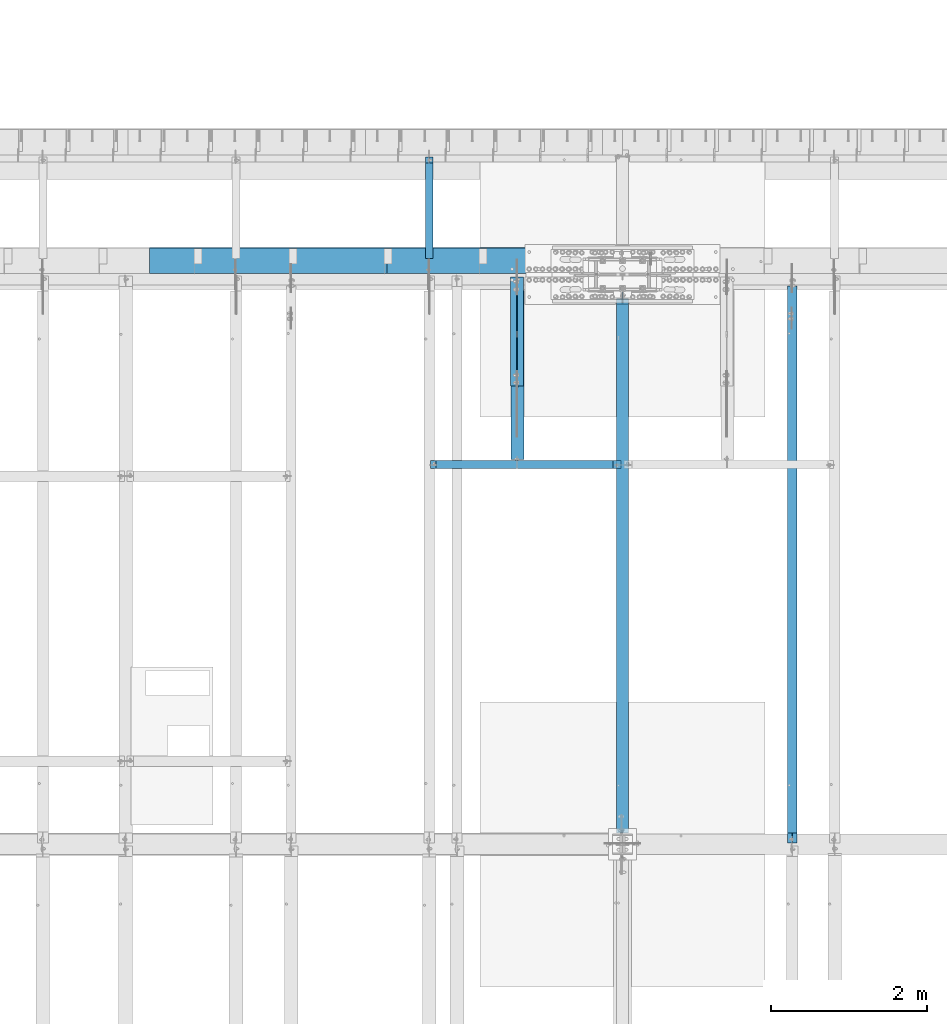
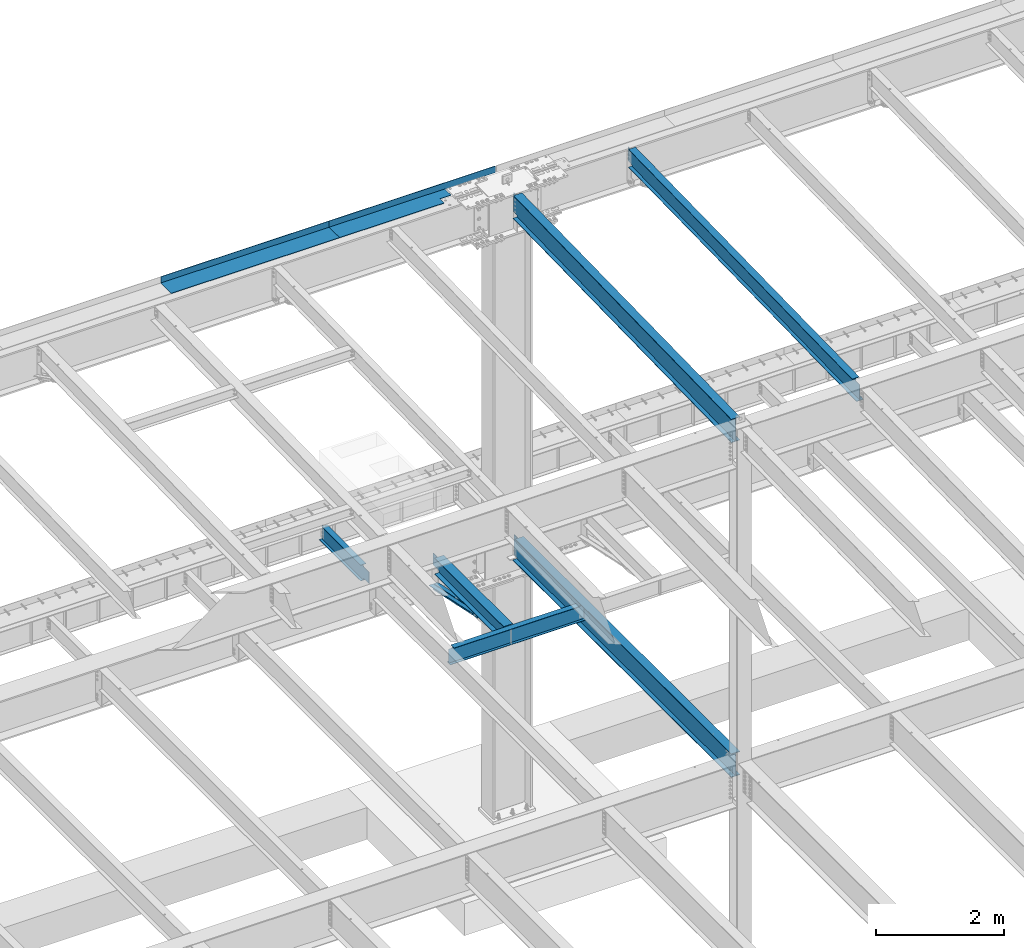
# One storey, part 1128 of 1763: 10 beams, 8 elements without a shape of their own.
"""IFC2X3 building model written with IfcOpenShell, lengths in millimetres."""

from ifc_helpers import new_model, si_unit, frame, origin_with_axes, place, context, subcontext, project, spatial, faceted_brep, material, type_object, element, aggregate, save


model = new_model("IFC2X3")

# Units and contexts
model_context = context("Model", 3, precision=1e-05, world=origin_with_axes())
body_context = subcontext(model_context, "Body", "Model", "MODEL_VIEW")
ifc_project = project(units=[si_unit("LENGTHUNIT", "METRE", prefix="MILLI"), si_unit("AREAUNIT", "SQUARE_METRE"), si_unit("VOLUMEUNIT", "CUBIC_METRE"), si_unit("MASSUNIT", "GRAM", prefix="KILO"), si_unit("TIMEUNIT", "SECOND"), si_unit("PLANEANGLEUNIT", "RADIAN"), si_unit("SOLIDANGLEUNIT", "STERADIAN"), si_unit("THERMODYNAMICTEMPERATUREUNIT", "DEGREE_CELSIUS"), si_unit("LUMINOUSINTENSITYUNIT", "LUMEN")], contexts=[model_context])

# Site, building, storey
site_placement = place(None, origin_with_axes())
site = spatial("IfcSite", under=ifc_project, at=site_placement, CompositionType="ELEMENT")
building_placement = place(site_placement, origin_with_axes())
building = spatial("IfcBuilding", under=site, at=building_placement, Name="Undefined", CompositionType="ELEMENT")
storey_placement = place(building_placement, origin_with_axes())
storey = spatial("IfcBuildingStorey", under=building, at=storey_placement, Name="Undefined", CompositionType="ELEMENT", Elevation=0.0)

# Assembly, beam
assembly_1_placement = place(storey_placement, origin_with_axes())
assembly_1 = element("IfcElementAssembly", 1, at=assembly_1_placement, inside=storey, Name="BEAM", AssemblyPlace="NOTDEFINED", PredefinedType="RIGID_FRAME")
ifc_material_1 = material(Name="STEEL/A992")
beam_type_1 = type_object("IfcBeamType", Name="W14X22", PredefinedType="NOTDEFINED")
beam_1_placement = place(assembly_1_placement, frame((-70311.7172736983, 44809.2121579121, 11421.5633921212), z_axis=(0.0, -0.0206852279954837, 0.999786037781472), x_axis=(0.0, 0.999786037781472, 0.0206852279954825)))
beam_1 = element("IfcBeam", 2, at=beam_1_placement, type_object=beam_type_1, material=ifc_material_1, Name="BEAM", ObjectType="W14X22", context=body_context, shape_type="Brep", body=[
    faceted_brep([(7162.77359555585, -3.17500000000291, -166.687500001777), (7162.77359555585, -63.5, -166.687500001777), (7162.77359555585, -63.5, -174.625000001772), (7162.77359555585, 63.5, -174.625000001772), (7162.77359555585, 63.5, -166.687500001777), (7162.77359555585, 3.17500000000291, -166.687500001777), (7162.77359555586, 3.17500000000291, -155.574999838074), (7162.77359555586, -3.17500000000291, -155.574999838074), (7163.74032547845, 3.17500000000291, -150.714920320039), (7163.74032547845, -3.17500000000291, -150.714920320039), (7166.49333937895, 3.17500000000291, -146.594743851894), (7166.49333937895, -3.17500000000291, -146.594743851894), (7170.61351584714, 3.17500000000291, -143.841729951426), (7170.61351584714, -3.17500000000291, -143.841729951426), (7175.47359536523, 3.17500000000291, -142.87500002884), (7175.47359536523, -3.17500000000291, -142.87500002884), (7289.55462988591, -3.17500000000291, -142.875000028898), (7289.55462988591, 3.17500000000291, -142.875000028898), (148.791145859177, 3.17500000000291, 166.687499999833), (148.791145859177, 63.5, 166.687499999833), (7169.123595556, 63.5, 166.68749999797), (7169.123595556, 3.17500000000291, 166.68749999797), (11.9924390219312, 3.17500000000291, -166.687499999878), (11.9924390219312, 63.5, -166.687499999878), (11.8282148869548, 63.5, -174.624999999871), (11.8282148869548, -63.5, -174.624999999871), (11.9924390219312, -63.5, -166.687499999878), (11.9924390219312, -3.17500000000291, -166.687499999878), (17.9976630864912, -3.17500000000291, 123.56500167838), (17.9976630864912, 3.17500000000291, 123.56500167838), (136.091146049795, -3.17500000000291, 123.565001678358), (136.091146049795, 3.17500000000291, 123.565001678358), (140.951225567893, -3.17500000000291, 124.531731600942), (140.951225567893, 3.17500000000291, 124.531731600942), (145.071402036083, -3.17500000000291, 127.284745501414), (145.071402036083, 3.17500000000291, 127.284745501414), (147.824415936586, -3.17500000000291, 131.404921969557), (147.824415936586, 3.17500000000291, 131.404921969557), (148.791145859177, -3.17500000000291, 136.265001487593), (148.791145859177, 3.17500000000291, 136.265001487593), (148.79114585917, -63.5, 174.624999999827), (148.79114585917, 63.5, 174.624999999827), (148.791145859177, -3.17500000000291, 166.687499999833), (148.791145859177, -63.5, 166.687499999833), (7169.123595556, -3.17500000000291, 166.68749999797), (7169.123595556, -63.5, 166.68749999797), (7169.123595556, -63.5, 174.624999997965), (7169.123595556, 63.5, 174.624999997965), (7169.123595556, -3.17500000000291, 142.875000542512), (7169.123595556, 3.17500000000291, 142.875000542512), (7170.0903254786, -3.17500000000291, 138.014921024478), (7170.0903254786, 3.17500000000291, 138.014921024478), (7172.8433393791, -3.17500000000291, 133.894744556334), (7172.8433393791, 3.17500000000291, 133.894744556334), (7176.96351584728, -3.17500000000291, 131.14173065586), (7176.96351584728, 3.17500000000291, 131.14173065586), (7181.82359536537, -3.17500000000291, 130.175000733272), (7181.82359536537, 3.17500000000291, 130.175000733272), (7295.20394014482, -3.17500000000291, 130.17500073325), (7295.20394014482, 3.17500000000291, 130.17500073325)], [[[0, 1, 2, 3, 4, 5, 6, 7]], [[7, 6, 8, 9]], [[9, 8, 10, 11]], [[11, 10, 12, 13]], [[13, 12, 14, 15]], [[16, 15, 14, 17]], [[18, 19, 20, 21]], [[22, 23, 24, 25, 26, 27, 28, 29]], [[30, 31, 29, 28]], [[32, 33, 31, 30]], [[34, 35, 33, 32]], [[36, 37, 35, 34]], [[38, 39, 37, 36]], [[40, 41, 19, 18, 39, 38, 42, 43]], [[43, 42, 44, 45]], [[40, 43, 45, 46]], [[41, 40, 46, 47]], [[19, 41, 47, 20]], [[46, 45, 44, 48, 49, 21, 20, 47]], [[50, 51, 49, 48]], [[52, 53, 51, 50]], [[54, 55, 53, 52]], [[56, 57, 55, 54]], [[58, 59, 57, 56]], [[59, 58, 16, 17]], [[12, 10, 8, 6, 5, 22, 29, 31, 33, 35, 37, 39, 18, 21, 49, 51, 53, 55, 57, 59, 17, 14]], [[23, 22, 5, 4]], [[24, 23, 4, 3]], [[25, 24, 3, 2]], [[26, 25, 2, 1]], [[27, 26, 1, 0]], [[58, 56, 54, 52, 50, 48, 44, 42, 38, 36, 34, 32, 30, 28, 27, 0, 7, 9, 11, 13, 15, 16]]]),
])
aggregate(assembly_1, [beam_1])

# Assembly, beams
assembly_2_placement = place(storey_placement, origin_with_axes())
assembly_2 = element("IfcElementAssembly", 3, at=assembly_2_placement, inside=storey, Name="ANGLE BRACE", AssemblyPlace="NOTDEFINED", PredefinedType="RIGID_FRAME")
ifc_material_2 = material(Name="STEEL/A36")
beam_type_2 = type_object("IfcBeamType", Name="L4X3X5/16", PredefinedType="NOTDEFINED")
beam_2_placement = place(assembly_2_placement, frame((-73888.0372736984, 50680.4564530846, 4820.75267554856), z_axis=(0.0, -0.2072236520035, -0.978293595016513), x_axis=(0.0, 0.978293600950479, -0.20722362398951)))
beam_2 = element("IfcBeam", 4, at=beam_2_placement, type_object=beam_type_2, material=ifc_material_2, Name="ANGLE BRACE", ObjectType="L4X3X5/16", context=body_context, shape_type="Brep", body=[
    faceted_brep([(1.45519152283669e-10, 38.0999999999985, -50.7999999999993), (1.45519152283669e-10, 38.0999999999985, 50.7999999999993), (1427.42255777739, 38.0999999999985, 50.7999999995518), (1427.42255777754, 38.0999999999985, -50.8000000004868), (-7.27595761418343e-11, 30.1624999999985, 50.8000000000211), (1427.42255777739, 30.1624999999985, 50.7999999995518), (7.27595761418343e-11, 30.1624999999985, -42.8625000000175), (1427.42255777754, 30.1624999999985, -42.8625000004868), (7.27595761418343e-11, -38.0999999999985, -42.8625000000175), (1427.42255777754, -38.0999999999985, -42.8625000004868), (-1.23691279441118e-10, -38.1000000000022, -50.7999999999993), (1427.42255777754, -38.0999999999985, -50.8000000004868)], [[[0, 1, 2, 3]], [[1, 4, 5, 2]], [[4, 6, 7, 5]], [[6, 8, 9, 7]], [[8, 10, 11, 9]], [[10, 0, 3, 11]], [[5, 7, 9, 11, 3, 2]], [[10, 8, 6, 4, 1, 0]]]),
])
beam_3_placement = place(assembly_2_placement, frame((-73802.3122736983, 52076.9355387112, 4524.94833056974), z_axis=(0.0, -0.2072236520035, -0.978293595016513), x_axis=(0.0, -0.978293595016513, 0.207223652003498)))
beam_3 = element("IfcBeam", 5, at=beam_3_placement, type_object=beam_type_2, material=ifc_material_2, Name="ANGLE BRACE", ObjectType="L4X3X5/16", context=body_context, shape_type="Brep", body=[
    faceted_brep([(1.45519152283669e-10, 38.0999999999985, -50.7999999999993), (1.45519152283669e-10, 38.0999999999985, 50.7999999999993), (1427.46422513096, 38.0999999999985, 50.7999999991189), (1427.46422513096, 38.0999999999985, -50.8000000008396), (-7.27595761418343e-11, 30.1624999999985, 50.8000000000211), (1427.46422513096, 30.1624999999985, 50.7999999991189), (7.27595761418343e-11, 30.1624999999985, -42.8625000000175), (1427.46422513096, 30.1624999999985, -42.8625000008433), (7.27595761418343e-11, -38.0999999999985, -42.8625000000175), (1427.46422513096, -38.0999999999985, -42.8625000008433), (-1.23691279441118e-10, -38.1000000000022, -50.7999999999993), (1427.46422513096, -38.0999999999985, -50.8000000008396)], [[[0, 1, 2, 3]], [[1, 4, 5, 2]], [[4, 6, 7, 5]], [[6, 8, 9, 7]], [[8, 10, 11, 9]], [[10, 0, 3, 11]], [[5, 7, 9, 11, 3, 2]], [[10, 8, 6, 4, 1, 0]]]),
])
aggregate(assembly_2, [beam_2, beam_3])

assembly_3_placement = place(storey_placement, origin_with_axes())
assembly_3 = element("IfcElementAssembly", 6, at=assembly_3_placement, inside=storey, Name="BEAM", AssemblyPlace="NOTDEFINED", PredefinedType="RIGID_FRAME")
beam_type_3 = type_object("IfcBeamType", PredefinedType="NOTDEFINED")
beam_4_placement = place(assembly_3_placement, frame((-74009.4807736983, 52133.5000002128, 11752.2624917654), z_axis=(-1.0, 0.0, 0.0), x_axis=(0.0, 1.0, 0.0)))
beam_4 = element("IfcBeam", 7, at=beam_4_placement, type_object=beam_type_3, material=ifc_material_2, Name="BENT_PLATE", context=body_context, shape_type="Brep", body=[
    faceted_brep([(0.0, -4.76250000000073, -386.556085937496), (0.0, 4.76250000000073, -386.556085937496), (133.349999999999, 4.76250000000073, -386.556085937496), (133.349999999999, -4.76250000000073, -386.556085937496), (133.349999999999, 4.76250000000073, -589.755976074215), (133.349999999999, -4.76250000000073, -589.755976074215), (327.02498779296, -4.76250000000073, -589.755976074215), (327.02498779296, 4.76250000000073, -589.755976074215), (327.024987792967, 4.76250000000073, -1505.74400000001), (327.024987792975, -4.76250000000073, -1505.74400000001), (336.549987792969, 4.76250000000073, 1505.74400000001), (0.0, 4.76250000000073, 1505.74400000001), (0.0, -4.76250000000073, 1505.74400000001), (327.024987792975, -4.76250000000073, 1505.74400000001), (327.024987792975, -122.237499999999, 1505.74400000001), (336.549987792969, -122.237499999999, 1505.74400000001), (336.549987792969, 4.76250000000073, -1505.74400000001), (336.549987792969, -122.237499999999, -1505.74400000001), (327.024987792975, -122.237499999999, -1505.74400000001), (327.024987792975, -99.5375007629373, -1505.74400000001)], [[[0, 1, 2, 3]], [[3, 2, 4, 5]], [[6, 7, 8, 9]], [[5, 4, 7, 6]], [[10, 11, 12, 13, 14, 15]], [[16, 10, 15, 17]], [[14, 18, 17, 15]], [[13, 6, 9, 19, 18, 14]], [[16, 17, 18, 19, 9, 8]], [[2, 1, 11, 10, 16, 8, 7, 4]], [[12, 11, 1, 0]], [[13, 12, 0, 3, 5, 6]]]),
])
beam_type_4 = type_object("IfcBeamType", PredefinedType="NOTDEFINED")
beam_5_placement = place(assembly_3_placement, frame((-77039.2247736984, 52133.5000002128, 11752.2624917654), z_axis=(-1.0, 0.0, 0.0), x_axis=(0.0, 1.0, 0.0)))
beam_5 = element("IfcBeam", 8, at=beam_5_placement, type_object=beam_type_4, material=ifc_material_2, Name="BENT_PLATE", context=body_context, shape_type="Brep", body=[
    faceted_brep([(0.0, -4.76249999999982, -1524.0), (0.0, -4.76249999999982, 1524.0), (0.0, 4.76249999999982, 1524.0), (0.0, 4.76249999999982, -1524.0), (336.549987792969, 4.76250000000073, 1524.0), (336.549987792969, 4.76250000000073, -1524.0), (327.024987792975, -4.76250000000073, -1524.0), (327.024987792967, -4.76250000000073, 1524.00000000001), (336.549987792969, -122.237499999999, 1524.0), (336.549987792969, -122.237499999999, -1524.0), (327.024987792975, -122.237499999999, 1524.0), (327.024987792975, -122.237499999999, -1524.0)], [[[0, 1, 2, 3]], [[3, 2, 4, 5]], [[1, 0, 6, 7]], [[5, 4, 8, 9]], [[4, 2, 1, 7, 10, 8]], [[7, 6, 11, 10]], [[6, 0, 3, 5, 9, 11]], [[10, 11, 9, 8]]]),
])
aggregate(assembly_3, [beam_4, beam_5])

# Assembly, beam
assembly_4_placement = place(storey_placement, origin_with_axes())
assembly_4 = element("IfcElementAssembly", 9, at=assembly_4_placement, inside=storey, Name="BEAM", AssemblyPlace="NOTDEFINED", PredefinedType="RIGID_FRAME")
beam_type_5 = type_object("IfcBeamType", Name="W12X16", PredefinedType="NOTDEFINED")
beam_6_placement = place(assembly_4_placement, frame((-74971.7706070317, 52120.8, 5041.9), z_axis=(0.0, 0.0, 1.0), x_axis=(0.0, 1.0, 0.0)))
beam_6 = element("IfcBeam", 10, at=beam_6_placement, type_object=beam_type_5, material=ifc_material_1, Name="BEAM", ObjectType="W12X16", context=body_context, shape_type="Brep", body=[
    faceted_brep([(20.6374999999971, -3.17500000000291, -114.3), (20.6374999999971, 3.17500000000291, -114.3), (192.087500190733, 3.17500000000291, -114.3), (192.087500190733, -3.17500000000291, -114.3), (196.94757970878, 3.17500000000291, -115.266729922588), (196.94757970878, -3.17500000000291, -115.266729922588), (201.067756176933, 3.17500000000291, -118.019743823066), (201.067756176933, -3.17500000000291, -118.019743823066), (203.820770077407, 3.17500000000291, -122.13992029122), (203.820770077407, -3.17500000000291, -122.13992029122), (204.787499999999, -3.17500000000291, -126.999999809265), (204.787499999999, 3.17500000000291, -126.999999809265), (204.787499999999, 3.17500000000291, -146.05), (204.787499999999, 50.8000000000029, -146.05), (204.787499999999, 50.8000000000029, -152.4), (204.787499999999, -50.8000000000029, -152.4), (204.787499999999, -50.8000000000029, -146.05), (204.787499999999, -3.17500000000291, -146.05), (1431.13125000001, 50.8000000000029, 146.05), (1431.13125000001, 3.17500000000291, 146.05), (204.787499999999, 3.17500000000291, 146.05), (204.787499999999, 50.8000000000029, 146.05), (192.087500190733, -3.17500000000291, 114.3), (192.087500190733, 3.17500000000291, 114.3), (20.6374999999971, 3.17500000000291, 114.3), (20.6374999999971, -3.17500000000291, 114.3), (196.94757970878, -3.17500000000291, 115.266729922588), (196.94757970878, 3.17500000000291, 115.266729922588), (201.067756176933, -3.17500000000291, 118.019743823066), (201.067756176933, 3.17500000000291, 118.019743823066), (203.820770077407, -3.17500000000291, 122.13992029122), (203.820770077407, 3.17500000000291, 122.13992029122), (204.787499999999, -3.17500000000291, 126.999999809265), (204.787499999999, 3.17500000000291, 126.999999809265), (1431.13125000001, -50.8000000000029, 152.4), (1431.13125000001, 50.8000000000029, 152.4), (204.787499999999, 50.8000000000029, 152.4), (204.787499999999, -50.8000000000029, 152.4), (1431.13125000001, -50.8000000000029, 146.05), (204.787499999999, -50.8000000000029, 146.05), (1431.13125000001, -3.17500000000291, 146.05), (204.787499999999, -3.17500000000291, 146.05), (1431.13125000001, -3.17500000000291, 139.440001487732), (1431.13125000001, 3.17500000000291, 139.440001487732), (1432.0979799226, -3.17500000000291, 134.579921969686), (1432.0979799226, 3.17500000000291, 134.579921969686), (1434.85099382307, -3.17500000000291, 130.459745501533), (1434.85099382307, 3.17500000000291, 130.459745501533), (1438.97117029122, -3.17500000000291, 127.706731601054), (1438.97117029122, 3.17500000000291, 127.706731601054), (1443.83124980927, -3.17500000000291, 126.740001678467), (1443.83124980927, 3.17500000000291, 126.740001678467), (1507.33125, -3.17500000000291, 126.740001678467), (1507.33125, 3.17500000000291, 126.740001678467), (1507.33125, -3.17500000000291, -146.05), (1507.33125, -50.8000000000029, -146.05), (1507.33125, -50.8000000000029, -152.4), (1507.33125, 50.8000000000029, -152.4), (1507.33125, 50.8000000000029, -146.05), (1507.33125, 3.17500000000291, -146.05)], [[[0, 1, 2, 3]], [[3, 2, 4, 5]], [[5, 4, 6, 7]], [[7, 6, 8, 9]], [[10, 11, 12, 13, 14, 15, 16, 17]], [[9, 8, 11, 10]], [[18, 19, 20, 21]], [[22, 23, 24, 25]], [[26, 27, 23, 22]], [[28, 29, 27, 26]], [[30, 31, 29, 28]], [[32, 33, 31, 30]], [[34, 35, 36, 37]], [[38, 34, 37, 39]], [[40, 38, 39, 41]], [[37, 36, 21, 20, 33, 32, 41, 39]], [[35, 18, 21, 36]], [[34, 38, 40, 42, 43, 19, 18, 35]], [[44, 45, 43, 42]], [[46, 47, 45, 44]], [[48, 49, 47, 46]], [[50, 51, 49, 48]], [[52, 53, 51, 50]], [[54, 55, 56, 57, 58, 59, 53, 52]], [[55, 54, 17, 16]], [[56, 55, 16, 15]], [[57, 56, 15, 14]], [[58, 57, 14, 13]], [[59, 58, 13, 12]], [[6, 4, 2, 1, 24, 23, 27, 29, 31, 33, 20, 19, 43, 45, 47, 49, 51, 53, 59, 12, 11, 8]], [[25, 24, 1, 0]], [[54, 52, 50, 48, 46, 44, 42, 40, 41, 32, 30, 28, 26, 22, 25, 0, 3, 5, 7, 9, 10, 17]]]),
])
aggregate(assembly_4, [beam_6])

assembly_5_placement = place(storey_placement, origin_with_axes())
assembly_5 = element("IfcElementAssembly", 11, at=assembly_5_placement, inside=storey, Name="BEAM", AssemblyPlace="NOTDEFINED", PredefinedType="RIGID_FRAME")
beam_type_6 = type_object("IfcBeamType", Name="W18X35", PredefinedType="NOTDEFINED")
beam_7_placement = place(assembly_5_placement, frame((-72491.0372736984, 44810.2629674943, 11370.7742614019), z_axis=(0.0, -0.0206852279954837, 0.999786037781472), x_axis=(0.0, 0.999786037781472, 0.0206852279954825)))
beam_7 = element("IfcBeam", 12, at=beam_7_placement, type_object=beam_type_6, material=ifc_material_1, Name="BEAM", ObjectType="W18X35", context=body_context, shape_type="Brep", body=[
    faceted_brep([(6981.85534172427, -3.96875, -214.312500001693), (6981.85534172427, -76.1999999999971, -214.312500001693), (6981.85534172427, -76.1999999999971, -225.425000001685), (6981.85534172427, 76.1999999999971, -225.425000001685), (6981.85534172427, 76.1999999999971, -214.312500001693), (6981.85534172427, 3.96875, -214.312500001693), (6981.85534172429, 3.96875, -200.284999820729), (6981.85534172429, -3.96875, -200.284999820729), (6982.82207164688, 3.96875, -195.424920302696), (6982.82207164688, -3.96875, -195.424920302696), (6985.57508554738, 3.96875, -191.304743834553), (6985.57508554738, -3.96875, -191.304743834553), (6989.69526201557, 3.96875, -188.551729934081), (6989.69526201557, -3.96875, -188.551729934081), (6994.55534153366, 3.96875, -187.585000011497), (6994.55534153366, -3.96875, -187.585000011497), (7092.27427279067, -3.96875, -187.585000011552), (7092.27427279067, 3.96875, -187.585000011552), (144.263502213013, 3.96875, 214.312499999811), (144.263502213013, 76.1999999999971, 214.312499999811), (6981.85534172432, 76.1999999999971, 214.312499997985), (6981.85534172432, 3.96875, 214.312499997985), (135.16548513544, -76.1999999999971, -225.424999999856), (135.395398924404, -76.1999999999971, -214.312499999864), (135.395398924404, -3.96875, -214.312499999864), (144.263502213013, -3.96875, 214.312499999811), (144.263502213013, -76.1999999999971, 214.312499999811), (144.493416001977, -76.1999999999971, 225.424999999803), (144.493416001977, 76.1999999999971, 225.424999999803), (135.395398924404, 3.96875, -214.312499999864), (135.395398924404, 76.1999999999971, -214.312499999864), (135.16548513544, 76.1999999999971, -225.424999999856), (6981.85534172432, -3.96875, 214.312499997985), (6981.85534172432, -76.1999999999971, 214.312499997985), (6981.85534172433, -76.1999999999971, 225.424999997977), (6981.85534172433, 76.1999999999971, 225.424999997977), (6981.85534172432, -3.96875, 199.765001475287), (6981.85534172432, 3.96875, 199.765001475287), (6982.82207164692, -3.96875, 194.904921957252), (6982.82207164692, 3.96875, 194.904921957252), (6985.57508554743, -3.96875, 190.784745489109), (6985.57508554743, 3.96875, 190.784745489109), (6989.69526201561, -3.96875, 188.031731588633), (6989.69526201561, 3.96875, 188.031731588633), (6994.55534153371, -3.96875, 187.065001666047), (6994.55534153371, 3.96875, 187.065001666047), (7100.02565199621, -3.96875, 187.065001666027), (7100.02565199621, 3.96875, 187.065001666027)], [[[0, 1, 2, 3, 4, 5, 6, 7]], [[7, 6, 8, 9]], [[9, 8, 10, 11]], [[11, 10, 12, 13]], [[13, 12, 14, 15]], [[16, 15, 14, 17]], [[18, 19, 20, 21]], [[22, 23, 24, 25, 26, 27, 28, 19, 18, 29, 30, 31]], [[26, 25, 32, 33]], [[27, 26, 33, 34]], [[28, 27, 34, 35]], [[19, 28, 35, 20]], [[34, 33, 32, 36, 37, 21, 20, 35]], [[38, 39, 37, 36]], [[40, 41, 39, 38]], [[42, 43, 41, 40]], [[44, 45, 43, 42]], [[46, 47, 45, 44]], [[47, 46, 16, 17]], [[12, 10, 8, 6, 5, 29, 18, 21, 37, 39, 41, 43, 45, 47, 17, 14]], [[30, 29, 5, 4]], [[31, 30, 4, 3]], [[22, 31, 3, 2]], [[23, 22, 2, 1]], [[24, 23, 1, 0]], [[46, 44, 42, 40, 38, 36, 32, 25, 24, 0, 7, 9, 11, 13, 15, 16]]]),
])
aggregate(assembly_5, [beam_7])

assembly_6_placement = place(storey_placement, origin_with_axes())
assembly_6 = element("IfcElementAssembly", 13, at=assembly_6_placement, inside=storey, Name="BEAM", AssemblyPlace="NOTDEFINED", PredefinedType="RIGID_FRAME")
beam_type_7 = type_object("IfcBeamType", Name="W18X40", PredefinedType="NOTDEFINED")
beam_8_placement = place(assembly_6_placement, frame((-72491.0372736984, 44805.6, 4967.2875), z_axis=(0.0, 0.0, 1.0), x_axis=(0.0, 1.0, 0.0)))
beam_8 = element("IfcBeam", 14, at=beam_8_placement, type_object=beam_type_7, material=ifc_material_1, Name="BEAM", ObjectType="W18X40", context=body_context, shape_type="Brep", body=[
    faceted_brep([(6937.37498732733, -76.1999999999971, 214.3125), (6937.37498732733, -3.96875, 214.3125), (6937.60420254865, -3.96875, 213.91549911499), (6937.60420254865, 3.96875, 213.91549911499), (6937.37498732733, 3.96875, 214.3125), (6937.37498732733, 76.1999999999971, 214.3125), (6930.04242606437, 76.1999999999971, 227.0125), (6930.04242606437, -76.1999999999971, 227.0125), (144.462499999994, 76.1999999999971, -214.3125), (144.462499999994, 71.199821507762, -214.3125), (144.462499999994, 3.96875, -214.3125), (6999.89240878766, 3.96875, -214.3125), (6999.89240878766, 76.1999999999971, -214.3125), (6890.76589898111, -3.96875, 204.211830867132), (6890.76589898111, 3.96875, 204.211830867132), (6911.97500305174, 3.96875, 213.91549911499), (6911.97500305174, -3.96875, 213.91549911499), (6887.72798328583, -3.96875, 201.276913128712), (6887.72798328583, 3.96875, 201.276913128712), (6887.20337863325, -3.96875, 197.085557278698), (6887.20337863325, 3.96875, 197.085557278698), (6889.42422216828, -3.96875, 193.492434974088), (6889.42422216828, 3.96875, 193.492434974088), (6893.40779237872, -3.96875, 192.0875), (6893.40779237872, 3.96875, 192.0875), (7089.77499999998, -3.96875, 192.0875), (7089.77499999998, 3.96875, 192.0875), (7089.77499999998, -3.96875, -192.0875), (7089.77499999998, 3.96875, -192.0875), (6980.86678896075, -3.96875, -192.0875), (6980.86678896075, 3.96875, -192.0875), (6976.88321875031, -3.96875, -193.492434974089), (6976.88321875031, 3.96875, -193.492434974089), (6974.66237521528, -3.96875, -197.085557278698), (6974.66237521528, 3.96875, -197.085557278698), (6975.18697986786, -3.96875, -201.276913128712), (6975.18697986786, 3.96875, -201.276913128712), (6978.22489556314, -3.96875, -204.211830867132), (6978.22489556314, 3.96875, -204.211830867132), (6999.43399963377, -3.96875, -213.91549911499), (6999.43399963377, 3.96875, -213.91549911499), (144.462499999994, -76.1999999999971, -227.0125), (144.462499999994, -14.2685700086731, -227.0125), (144.462499999994, -5.73107306084421, -227.0125), (144.462499999994, 71.2001784793538, -227.0125), (144.462499999994, 76.1999999999971, -227.0125), (7007.22459707105, 76.1999999999971, -227.0125), (7007.22459707105, -76.1999999999971, -227.0125), (144.462499999994, -76.1999999999971, -214.3125), (6999.89240878766, -76.1999999999971, -214.3125), (144.462499999994, -3.96875, -214.3125), (144.462499999994, -5.73143003243604, -214.3125), (144.462499999994, -14.268926980265, -214.3125), (6999.89240878766, -3.96875, -214.3125), (144.462499999994, -3.96875, -205.614753375452), (144.462499999994, -3.96875, 214.3125), (144.462499999994, -76.1999999999971, 214.3125), (144.462499999994, -76.1999999999971, 227.0125), (144.462499999994, 76.1999999999971, 227.0125), (144.462499999994, 76.1999999999971, 214.3125), (144.462499999994, 3.96875, 214.3125), (144.462499999994, 3.96875, -205.614530268201)], [[[0, 1, 2, 3, 4, 5, 6, 7]], [[8, 9, 10, 11, 12]], [[13, 14, 15, 16]], [[17, 18, 14, 13]], [[19, 20, 18, 17]], [[21, 22, 20, 19]], [[23, 24, 22, 21]], [[24, 23, 25, 26]], [[25, 27, 28, 26]], [[29, 30, 28, 27]], [[31, 32, 30, 29]], [[33, 34, 32, 31]], [[35, 36, 34, 33]], [[37, 38, 36, 35]], [[38, 37, 39, 40]], [[41, 42, 43, 44, 45, 46, 47]], [[48, 41, 47, 49]], [[50, 51, 52, 48, 49, 53]], [[47, 46, 12, 11, 40, 39, 53, 49]], [[45, 8, 12, 46]], [[44, 43, 42, 41, 48, 52, 51, 50, 54, 55, 56, 57, 58, 59, 60, 61, 10, 9, 8, 45]], [[57, 56, 0, 7]], [[58, 57, 7, 6]], [[59, 58, 6, 5]], [[60, 59, 5, 4]], [[15, 14, 18, 20, 22, 24, 26, 28, 30, 32, 34, 36, 38, 40, 11, 10, 61, 60, 4, 3]], [[16, 15, 3, 2]], [[55, 54, 50, 53, 39, 37, 35, 33, 31, 29, 27, 25, 23, 21, 19, 17, 13, 16, 2, 1]], [[56, 55, 1, 0]]]),
])
aggregate(assembly_6, [beam_8])

assembly_7_placement = place(storey_placement, origin_with_axes())
assembly_7 = element("IfcElementAssembly", 15, at=assembly_7_placement, inside=storey, Name="BEAM", AssemblyPlace="NOTDEFINED", PredefinedType="RIGID_FRAME")
beam_type_8 = type_object("IfcBeamType", Name="W12X26", PredefinedType="NOTDEFINED")
beam_9_placement = place(assembly_7_placement, frame((-73837.2372736984, 49682.4, 5038.725), z_axis=(0.0, 0.0, 1.0), x_axis=(0.0, 1.0, 0.0)))
beam_9 = element("IfcBeam", 16, at=beam_9_placement, type_object=beam_type_8, material=ifc_material_1, Name="BEAM", ObjectType="W12X26", context=body_context, shape_type="Brep", body=[
    faceted_brep([(2233.6125, -3.17500000000291, -146.05), (2233.6125, -82.5500000000029, -146.05), (2233.6125, -82.5500000000029, -155.575), (2233.6125, 82.5500000000029, -155.575), (2233.6125, 82.5500000000029, -146.05), (2233.6125, 3.17500000000291, -146.05), (2233.6125, 3.17500000000291, -123.824999809265), (2233.6125, -3.17500000000291, -123.824999809265), (2234.57922992259, 3.17500000000291, -118.96492029122), (2234.57922992259, -3.17500000000291, -118.96492029122), (2237.33224382307, 3.17500000000291, -114.844743823066), (2237.33224382307, -3.17500000000291, -114.844743823066), (2241.45242029122, 3.17500000000291, -112.091729922588), (2241.45242029122, -3.17500000000291, -112.091729922588), (2246.31249980927, 3.17500000000291, -111.125), (2246.31249980927, -3.17500000000291, -111.125), (2417.7625, -3.17500000000291, -111.125), (2417.7625, 3.17500000000291, -111.125), (65.8812499999913, 3.17500000000291, 146.05), (65.8812499999913, 82.5500000000029, 146.05), (2233.6125, 82.5500000000029, 146.05), (2233.6125, 3.17500000000291, 146.05), (65.8812499999913, -3.17500000000291, -123.824999809265), (65.8812499999913, 3.17500000000291, -123.824999809265), (65.8812499999913, 3.17500000000291, -146.05), (65.8812499999913, 82.5500000000029, -146.05), (65.8812499999913, 82.5500000000029, -155.575), (65.8812499999913, -82.5500000000029, -155.575), (65.8812499999913, -82.5500000000029, -146.05), (65.8812499999913, -3.17500000000291, -146.05), (64.9145200774001, -3.17500000000291, -118.96492029122), (64.9145200774001, 3.17500000000291, -118.96492029122), (62.1615061769262, -3.17500000000291, -114.844743823066), (62.1615061769262, 3.17500000000291, -114.844743823066), (58.0413297087725, -3.17500000000291, -112.091729922588), (58.0413297087725, 3.17500000000291, -112.091729922588), (53.1812501907261, -3.17500000000291, -111.125), (53.1812501907261, 3.17500000000291, -111.125), (15.0812499999956, -3.17500000000291, -111.125), (15.0812499999956, 3.17500000000291, -111.125), (15.0812499999956, -3.17500000000291, 117.475), (15.0812499999956, 3.17500000000291, 117.475), (53.1812501907261, -3.17500000000291, 117.475), (53.1812501907261, 3.17500000000291, 117.475), (58.0413297087725, -3.17500000000291, 118.441729922588), (58.0413297087725, 3.17500000000291, 118.441729922588), (62.1615061769262, -3.17500000000291, 121.194743823066), (62.1615061769262, 3.17500000000291, 121.194743823066), (64.9145200774001, -3.17500000000291, 125.31492029122), (64.9145200774001, 3.17500000000291, 125.31492029122), (65.8812499999913, -3.17500000000291, 130.174999809266), (65.8812499999913, 3.17500000000291, 130.174999809266), (65.8812499999913, -82.5500000000029, 155.575), (65.8812499999913, 82.5500000000029, 155.575), (65.8812499999913, -3.17500000000291, 146.05), (65.8812499999913, -82.5500000000029, 146.05), (2233.6125, -3.17500000000291, 146.05), (2233.6125, -82.5500000000029, 146.05), (2233.6125, -82.5500000000029, 155.575), (2233.6125, 82.5500000000029, 155.575), (2233.6125, -3.17500000000291, 123.824999809265), (2233.6125, 3.17500000000291, 123.824999809265), (2234.57922992259, -3.17500000000291, 118.96492029122), (2234.57922992259, 3.17500000000291, 118.96492029122), (2237.33224382307, -3.17500000000291, 114.844743823066), (2237.33224382307, 3.17500000000291, 114.844743823066), (2241.45242029122, -3.17500000000291, 112.091729922588), (2241.45242029122, 3.17500000000291, 112.091729922588), (2246.31249980927, -3.17500000000291, 111.125), (2246.31249980927, 3.17500000000291, 111.125), (2417.7625, -3.17500000000291, 111.125), (2417.7625, 3.17500000000291, 111.125)], [[[0, 1, 2, 3, 4, 5, 6, 7]], [[7, 6, 8, 9]], [[9, 8, 10, 11]], [[11, 10, 12, 13]], [[13, 12, 14, 15]], [[16, 15, 14, 17]], [[18, 19, 20, 21]], [[22, 23, 24, 25, 26, 27, 28, 29]], [[30, 31, 23, 22]], [[32, 33, 31, 30]], [[34, 35, 33, 32]], [[36, 37, 35, 34]], [[38, 39, 37, 36]], [[40, 41, 39, 38]], [[42, 43, 41, 40]], [[44, 45, 43, 42]], [[46, 47, 45, 44]], [[48, 49, 47, 46]], [[50, 51, 49, 48]], [[52, 53, 19, 18, 51, 50, 54, 55]], [[55, 54, 56, 57]], [[52, 55, 57, 58]], [[53, 52, 58, 59]], [[19, 53, 59, 20]], [[58, 57, 56, 60, 61, 21, 20, 59]], [[62, 63, 61, 60]], [[64, 65, 63, 62]], [[66, 67, 65, 64]], [[68, 69, 67, 66]], [[70, 71, 69, 68]], [[71, 70, 16, 17]], [[12, 10, 8, 6, 5, 24, 23, 31, 33, 35, 37, 39, 41, 43, 45, 47, 49, 51, 18, 21, 61, 63, 65, 67, 69, 71, 17, 14]], [[25, 24, 5, 4]], [[26, 25, 4, 3]], [[27, 26, 3, 2]], [[28, 27, 2, 1]], [[29, 28, 1, 0]], [[70, 68, 66, 64, 62, 60, 56, 54, 50, 48, 46, 44, 42, 40, 38, 36, 34, 32, 30, 22, 29, 0, 7, 9, 11, 13, 15, 16]]]),
])
aggregate(assembly_7, [beam_9])

assembly_8_placement = place(storey_placement, origin_with_axes())
assembly_8 = element("IfcElementAssembly", 17, at=assembly_8_placement, inside=storey, Name="BEAM", AssemblyPlace="NOTDEFINED", PredefinedType="RIGID_FRAME")
beam_type_9 = type_object("IfcBeamType", Name="W12X14", PredefinedType="NOTDEFINED")
beam_10_placement = place(assembly_8_placement, frame((-74971.7706070317, 49682.4, 5043.4875), z_axis=(0.0, 0.0, 1.0), x_axis=(1.0, 0.0, 0.0)))
beam_10 = element("IfcBeam", 18, at=beam_10_placement, type_object=beam_type_9, material=ifc_material_1, Name="BEAM", ObjectType="W12X14", context=body_context, shape_type="Brep", body=[
    faceted_brep([(2356.11458333334, -50.8000000000029, 150.8125), (2356.11458333334, -50.8000000000029, 144.4625), (2356.11458333334, -2.38124999999854, 144.4625), (2356.11458333334, -2.38124999999854, 131.502501487732), (2356.11458333334, 2.38124999999854, 131.502501487732), (2356.11458333334, 2.38124999999854, 144.4625), (2356.11458333334, 50.8000000000029, 144.4625), (2356.11458333334, 50.8000000000029, 150.8125), (2357.08131325593, -2.38124999999854, 126.642421969686), (2357.08131325593, 2.38124999999854, 126.642421969686), (2359.83432715641, -2.38124999999854, 122.522245501533), (2359.83432715641, 2.38124999999854, 122.522245501533), (2363.95450362457, -2.38124999999854, 119.769231601054), (2363.95450362457, 2.38124999999854, 119.769231601054), (2368.81458314261, -2.38124999999854, 118.802501678467), (2368.81458314261, 2.38124999999854, 118.802501678467), (2464.06458333334, -2.38124999999854, 118.802501678467), (2464.06458333334, 2.38124999999854, 118.802501678467), (85.724999999984, -50.8000000000029, 150.8125), (85.724999999984, 50.8000000000029, 150.8125), (85.724999999984, 50.8000000000029, 144.4625), (85.724999999984, 2.38124999999854, 144.4625), (85.724999999984, 2.38124999999854, 137.852501487731), (85.724999999984, -2.38124999999854, 137.852501487731), (85.724999999984, -2.38124999999854, 144.4625), (85.724999999984, -50.8000000000029, 144.4625), (84.7582700773928, 2.38124999999854, 132.992421969686), (84.7582700773928, -2.38124999999854, 132.992421969686), (82.0052561769189, 2.38124999999854, 128.872245501532), (82.0052561769189, -2.38124999999854, 128.872245501532), (77.8850797087653, 2.38124999999854, 126.119231601054), (77.8850797087653, -2.38124999999854, 126.119231601054), (73.0250001907189, 2.38124999999854, 125.152501678466), (73.0250001907189, -2.38124999999854, 125.152501678466), (15.875, 2.38124999999854, 125.152501678466), (15.875, -2.38124999999854, 125.152501678466), (15.875, 2.38124999999854, -144.4625), (15.875, 50.8000000000029, -144.4625), (15.875, 50.8000000000029, -150.8125), (15.875, -50.8000000000029, -150.8125), (15.875, -50.8000000000029, -144.4625), (15.875, -2.38124999999854, -144.4625), (2464.06458333334, 2.38124999999854, -144.4625), (2464.06458333334, 50.8000000000029, -144.4625), (2464.06458333334, 50.8000000000029, -150.8125), (2464.06458333334, -50.8000000000029, -150.8125), (2464.06458333334, -50.8000000000029, -144.4625), (2464.06458333334, -2.38124999999854, -144.4625)], [[[0, 1, 2, 3, 4, 5, 6, 7]], [[8, 9, 4, 3]], [[10, 11, 9, 8]], [[12, 13, 11, 10]], [[14, 15, 13, 12]], [[16, 17, 15, 14]], [[18, 19, 20, 21, 22, 23, 24, 25]], [[23, 22, 26, 27]], [[27, 26, 28, 29]], [[29, 28, 30, 31]], [[31, 30, 32, 33]], [[33, 32, 34, 35]], [[36, 37, 38, 39, 40, 41, 35, 34]], [[37, 36, 42, 43]], [[38, 37, 43, 44]], [[39, 38, 44, 45]], [[40, 39, 45, 46]], [[41, 40, 46, 47]], [[12, 10, 8, 3, 2, 24, 23, 27, 29, 31, 33, 35, 41, 47, 16, 14]], [[25, 24, 2, 1]], [[18, 25, 1, 0]], [[19, 18, 0, 7]], [[20, 19, 7, 6]], [[21, 20, 6, 5]], [[42, 36, 34, 32, 30, 28, 26, 22, 21, 5, 4, 9, 11, 13, 15, 17]], [[47, 46, 45, 44, 43, 42, 17, 16]]]),
])
aggregate(assembly_8, [beam_10])

save(model, "model.ifc")
